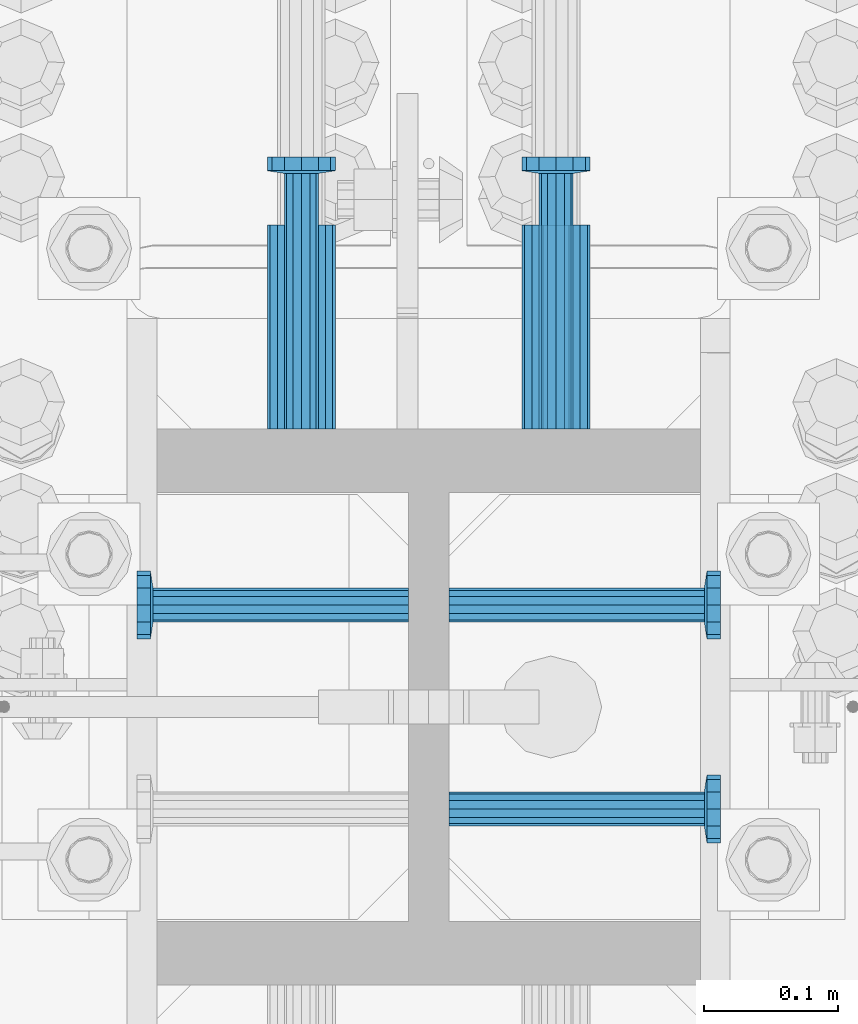
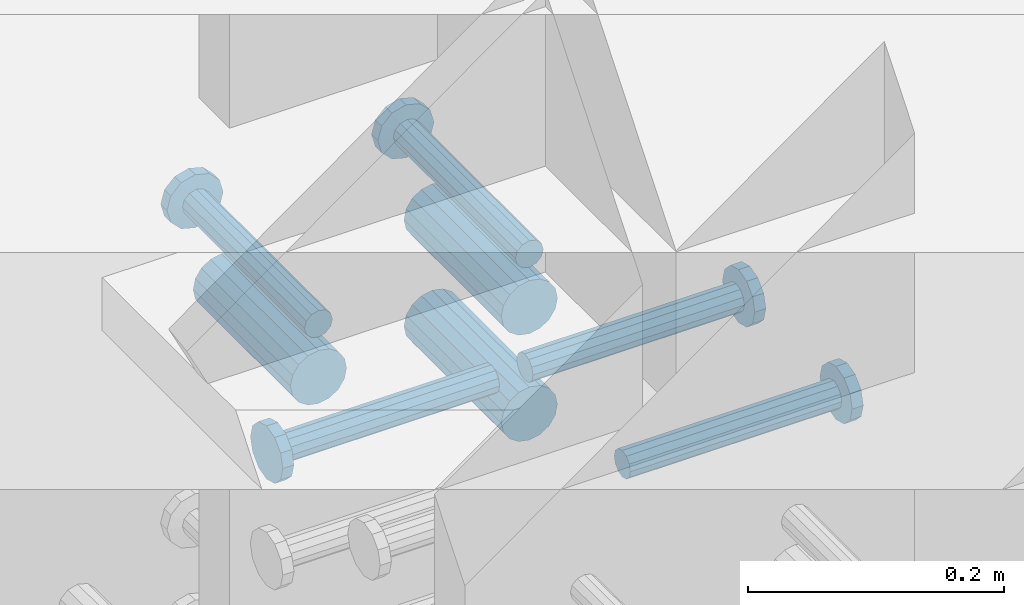
# One storey, part 1292 of 1763: 8 beams, 1 element without a shape of its own.
"""IFC2X3 building model written with IfcOpenShell, lengths in millimetres."""

from ifc_helpers import new_model, si_unit, frame, origin_with_axes, place, context, subcontext, project, spatial, faceted_brep, material, type_object, element, aggregate, save


model = new_model("IFC2X3")

# Units and contexts
model_context = context("Model", 3, precision=1e-05, world=origin_with_axes())
body_context = subcontext(model_context, "Body", "Model", "MODEL_VIEW")
ifc_project = project(units=[si_unit("LENGTHUNIT", "METRE", prefix="MILLI"), si_unit("AREAUNIT", "SQUARE_METRE"), si_unit("VOLUMEUNIT", "CUBIC_METRE"), si_unit("MASSUNIT", "GRAM", prefix="KILO"), si_unit("TIMEUNIT", "SECOND"), si_unit("PLANEANGLEUNIT", "RADIAN"), si_unit("SOLIDANGLEUNIT", "STERADIAN"), si_unit("THERMODYNAMICTEMPERATUREUNIT", "DEGREE_CELSIUS"), si_unit("LUMINOUSINTENSITYUNIT", "LUMEN")], contexts=[model_context])

# Site, building, storey
site_placement = place(None, origin_with_axes())
site = spatial("IfcSite", under=ifc_project, at=site_placement, CompositionType="ELEMENT")
building_placement = place(site_placement, origin_with_axes())
building = spatial("IfcBuilding", under=site, at=building_placement, Name="Undefined", CompositionType="ELEMENT")
storey_placement = place(building_placement, origin_with_axes())
storey = spatial("IfcBuildingStorey", under=building, at=storey_placement, Name="Undefined", CompositionType="ELEMENT", Elevation=0.0)

# Assembly, beams
assembly_placement = place(storey_placement, origin_with_axes())
assembly = element("IfcElementAssembly", 1, at=assembly_placement, inside=storey, Name="COLUMN", AssemblyPlace="NOTDEFINED", PredefinedType="RIGID_FRAME")
ifc_material_1 = material(Name="STEEL/A706-GR.80")
beam_type_1 = type_object("IfcBeamType", PredefinedType="NOTDEFINED")
beam_1_placement = place(assembly_placement, frame((-23932.5872736985, -13508.0376141552, 4775.20000000009), z_axis=(0.0, 0.0, 1.0), x_axis=(0.0, 1.0, 0.0)))
beam_1 = element("IfcBeam", 2, at=beam_1_placement, type_object=beam_type_1, material=ifc_material_1, Name="HALF COUPLER F", context=body_context, shape_type="Brep", body=[
    faceted_brep([(32.7659999999996, -8.95349999999962, -15.507916905568), (32.7659999999996, 0.0, -17.9070000000002), (32.7659999999996, 8.95349999999962, -15.507916905568), (32.7659999999996, 15.507916905568, -8.95350000000008), (32.7659999999996, 17.9069999999992, 0.0), (32.7659999999996, 15.507916905568, 8.95350000000008), (32.7659999999996, 8.95349999999962, 15.507916905568), (32.7659999999996, 0.0, 17.9070000000002), (32.7659999999996, -8.95349999999962, 15.507916905568), (32.7659999999996, -15.507916905568, 8.95350000000008), (32.7659999999996, -17.9069999999992, 0.0), (32.7659999999996, -15.507916905568, -8.95350000000008), (152.400103102711, -15.507916905568, 8.95350000000008), (152.400103102711, -8.95349999999962, 15.507916905568), (152.400103102711, -17.9069999999992, 0.0), (152.400103102711, -15.507916905568, -8.95350000000008), (152.400103102711, -8.95349999999962, -15.507916905568), (152.400103102711, 0.0, -17.9070000000002), (152.400103102711, 8.95349999999962, -15.507916905568), (152.400103102711, 15.507916905568, -8.95350000000008), (152.400103102711, 17.9069999999992, 0.0), (152.400103102711, 15.507916905568, 8.95350000000008), (152.400103102711, 8.95349999999962, 15.507916905568), (152.400103102711, 0.0, 17.9070000000002), (0.0, -23.466540125788, 9.72015918207308), (0.0, -17.9605122421381, 17.9605122421385), (0.0, -9.72015918207398, 23.4665401257867), (0.0, 0.0, 25.4000000000001), (0.0, 9.72015918207398, 23.4665401257867), (0.0, 17.9605122421381, 17.9605122421385), (0.0, 23.466540125788, 9.72015918207308), (0.0, 25.4000000000015, 0.0), (0.0, 23.466540125788, -9.72015918207308), (0.0, 17.9605122421381, -17.9605122421385), (0.0, 9.72015918207398, -23.4665401257867), (0.0, 0.0, -25.4000000000001), (0.0, -9.72015918207398, -23.4665401257867), (0.0, -17.9605122421381, -17.9605122421385), (0.0, -23.466540125788, -9.72015918207308), (0.0, -25.4000000000015, 0.0), (152.400103102711, -25.4000000000015, 0.0), (152.400103102711, -23.466540125788, 9.72015918207308), (152.400103102711, -17.9605122421381, 17.9605122421385), (152.400103102711, -9.72015918207398, 23.4665401257867), (152.400103102711, 0.0, 25.4000000000001), (152.400103102711, 9.72015918207398, 23.4665401257867), (152.400103102711, 17.9605122421381, 17.9605122421385), (152.400103102711, 23.466540125788, 9.72015918207308), (152.400103102711, 25.4000000000015, 0.0), (152.400103102711, 23.466540125788, -9.72015918207308), (152.400103102711, 17.9605122421381, -17.9605122421385), (152.400103102711, 9.72015918207398, -23.4665401257867), (152.400103102711, 0.0, -25.4000000000001), (152.400103102711, -9.72015918207398, -23.4665401257867), (152.400103102711, -17.9605122421381, -17.9605122421385), (152.400103102711, -23.466540125788, -9.72015918207308)], [[[0, 1, 2, 3, 4, 5, 6, 7, 8, 9, 10, 11]], [[12, 9, 8, 13]], [[14, 10, 9, 12]], [[15, 11, 10, 14]], [[16, 0, 11, 15]], [[17, 1, 0, 16]], [[18, 2, 1, 17]], [[19, 3, 2, 18]], [[20, 4, 3, 19]], [[21, 5, 4, 20]], [[22, 6, 5, 21]], [[23, 7, 6, 22]], [[13, 8, 7, 23]], [[24, 25, 26, 27, 28, 29, 30, 31, 32, 33, 34, 35, 36, 37, 38, 39]], [[24, 39, 40, 41]], [[25, 24, 41, 42]], [[26, 25, 42, 43]], [[27, 26, 43, 44]], [[28, 27, 44, 45]], [[29, 28, 45, 46]], [[30, 29, 46, 47]], [[31, 30, 47, 48]], [[32, 31, 48, 49]], [[33, 32, 49, 50]], [[34, 33, 50, 51]], [[35, 34, 51, 52]], [[36, 35, 52, 53]], [[37, 36, 53, 54]], [[38, 37, 54, 55]], [[39, 38, 55, 40]], [[54, 53, 52, 51, 50, 49, 48, 47, 46, 45, 44, 43, 42, 41, 40, 55], [21, 20, 19, 18, 17, 16, 15, 14, 12, 13, 23, 22]]]),
])
beam_2_placement = place(assembly_placement, frame((-24123.0872736984, -13508.0374079487, 4876.80000000009), z_axis=(0.0, 0.0, 1.0), x_axis=(0.0, 1.0, 0.0)))
beam_2 = element("IfcBeam", 3, at=beam_2_placement, type_object=beam_type_1, material=ifc_material_1, Name="HALF COUPLER F", context=body_context, shape_type="Brep", body=[
    faceted_brep([(32.7659999999996, -8.95349999999962, -15.507916905568), (32.7659999999996, 0.0, -17.9070000000002), (32.7659999999996, 8.95349999999962, -15.507916905568), (32.7659999999996, 15.507916905568, -8.95350000000008), (32.7659999999996, 17.9069999999992, 0.0), (32.7659999999996, 15.507916905568, 8.95350000000008), (32.7659999999996, 8.95349999999962, 15.507916905568), (32.7659999999996, 0.0, 17.9070000000002), (32.7659999999996, -8.95349999999962, 15.507916905568), (32.7659999999996, -15.507916905568, 8.95350000000008), (32.7659999999996, -17.9069999999992, 0.0), (32.7659999999996, -15.507916905568, -8.95350000000008), (152.400103102711, -15.507916905568, 8.95350000000008), (152.400103102711, -8.95349999999962, 15.507916905568), (152.400103102711, -17.9069999999992, 0.0), (152.400103102711, -15.507916905568, -8.95350000000008), (152.400103102711, -8.95349999999962, -15.507916905568), (152.400103102711, 0.0, -17.9070000000002), (152.400103102711, 8.95349999999962, -15.507916905568), (152.400103102711, 15.507916905568, -8.95350000000008), (152.400103102711, 17.9069999999992, 0.0), (152.400103102711, 15.507916905568, 8.95350000000008), (152.400103102711, 8.95349999999962, 15.507916905568), (152.400103102711, 0.0, 17.9070000000002), (0.0, -23.466540125788, 9.72015918207308), (0.0, -17.9605122421381, 17.9605122421385), (0.0, -9.72015918207398, 23.4665401257867), (0.0, 0.0, 25.4000000000001), (0.0, 9.72015918207398, 23.4665401257867), (0.0, 17.9605122421381, 17.9605122421385), (0.0, 23.466540125788, 9.72015918207308), (0.0, 25.4000000000015, 0.0), (0.0, 23.466540125788, -9.72015918207308), (0.0, 17.9605122421381, -17.9605122421385), (0.0, 9.72015918207398, -23.4665401257867), (0.0, 0.0, -25.4000000000001), (0.0, -9.72015918207398, -23.4665401257867), (0.0, -17.9605122421381, -17.9605122421385), (0.0, -23.466540125788, -9.72015918207308), (0.0, -25.4000000000015, 0.0), (152.400103102711, -25.4000000000015, 0.0), (152.400103102711, -23.466540125788, 9.72015918207308), (152.400103102711, -17.9605122421381, 17.9605122421385), (152.400103102711, -9.72015918207398, 23.4665401257867), (152.400103102711, 0.0, 25.4000000000001), (152.400103102711, 9.72015918207398, 23.4665401257867), (152.400103102711, 17.9605122421381, 17.9605122421385), (152.400103102711, 23.466540125788, 9.72015918207308), (152.400103102711, 25.4000000000015, 0.0), (152.400103102711, 23.466540125788, -9.72015918207308), (152.400103102711, 17.9605122421381, -17.9605122421385), (152.400103102711, 9.72015918207398, -23.4665401257867), (152.400103102711, 0.0, -25.4000000000001), (152.400103102711, -9.72015918207398, -23.4665401257867), (152.400103102711, -17.9605122421381, -17.9605122421385), (152.400103102711, -23.466540125788, -9.72015918207308)], [[[0, 1, 2, 3, 4, 5, 6, 7, 8, 9, 10, 11]], [[12, 9, 8, 13]], [[14, 10, 9, 12]], [[15, 11, 10, 14]], [[16, 0, 11, 15]], [[17, 1, 0, 16]], [[18, 2, 1, 17]], [[19, 3, 2, 18]], [[20, 4, 3, 19]], [[21, 5, 4, 20]], [[22, 6, 5, 21]], [[23, 7, 6, 22]], [[13, 8, 7, 23]], [[24, 25, 26, 27, 28, 29, 30, 31, 32, 33, 34, 35, 36, 37, 38, 39]], [[24, 39, 40, 41]], [[25, 24, 41, 42]], [[26, 25, 42, 43]], [[27, 26, 43, 44]], [[28, 27, 44, 45]], [[29, 28, 45, 46]], [[30, 29, 46, 47]], [[31, 30, 47, 48]], [[32, 31, 48, 49]], [[33, 32, 49, 50]], [[34, 33, 50, 51]], [[35, 34, 51, 52]], [[36, 35, 52, 53]], [[37, 36, 53, 54]], [[38, 37, 54, 55]], [[39, 38, 55, 40]], [[54, 53, 52, 51, 50, 49, 48, 47, 46, 45, 44, 43, 42, 41, 40, 55], [21, 20, 19, 18, 17, 16, 15, 14, 12, 13, 23, 22]]]),
])
beam_3_placement = place(assembly_placement, frame((-23932.5872736985, -13508.0374766842, 4876.80000000009), z_axis=(0.0, 0.0, 1.0), x_axis=(0.0, 1.0, 0.0)))
beam_3 = element("IfcBeam", 4, at=beam_3_placement, type_object=beam_type_1, material=ifc_material_1, Name="HALF COUPLER F", context=body_context, shape_type="Brep", body=[
    faceted_brep([(32.7659999999996, -8.95349999999962, -15.507916905568), (32.7659999999996, 0.0, -17.9070000000002), (32.7659999999996, 8.95349999999962, -15.507916905568), (32.7659999999996, 15.507916905568, -8.95350000000008), (32.7659999999996, 17.9069999999992, 0.0), (32.7659999999996, 15.507916905568, 8.95350000000008), (32.7659999999996, 8.95349999999962, 15.507916905568), (32.7659999999996, 0.0, 17.9070000000002), (32.7659999999996, -8.95349999999962, 15.507916905568), (32.7659999999996, -15.507916905568, 8.95350000000008), (32.7659999999996, -17.9069999999992, 0.0), (32.7659999999996, -15.507916905568, -8.95350000000008), (152.400103102711, -15.507916905568, 8.95350000000008), (152.400103102711, -8.95349999999962, 15.507916905568), (152.400103102711, -17.9069999999992, 0.0), (152.400103102711, -15.507916905568, -8.95350000000008), (152.400103102711, -8.95349999999962, -15.507916905568), (152.400103102711, 0.0, -17.9070000000002), (152.400103102711, 8.95349999999962, -15.507916905568), (152.400103102711, 15.507916905568, -8.95350000000008), (152.400103102711, 17.9069999999992, 0.0), (152.400103102711, 15.507916905568, 8.95350000000008), (152.400103102711, 8.95349999999962, 15.507916905568), (152.400103102711, 0.0, 17.9070000000002), (0.0, -23.466540125788, 9.72015918207308), (0.0, -17.9605122421381, 17.9605122421385), (0.0, -9.72015918207398, 23.4665401257867), (0.0, 0.0, 25.4000000000001), (0.0, 9.72015918207398, 23.4665401257867), (0.0, 17.9605122421381, 17.9605122421385), (0.0, 23.466540125788, 9.72015918207308), (0.0, 25.4000000000015, 0.0), (0.0, 23.466540125788, -9.72015918207308), (0.0, 17.9605122421381, -17.9605122421385), (0.0, 9.72015918207398, -23.4665401257867), (0.0, 0.0, -25.4000000000001), (0.0, -9.72015918207398, -23.4665401257867), (0.0, -17.9605122421381, -17.9605122421385), (0.0, -23.466540125788, -9.72015918207308), (0.0, -25.4000000000015, 0.0), (152.400103102711, -25.4000000000015, 0.0), (152.400103102711, -23.466540125788, 9.72015918207308), (152.400103102711, -17.9605122421381, 17.9605122421385), (152.400103102711, -9.72015918207398, 23.4665401257867), (152.400103102711, 0.0, 25.4000000000001), (152.400103102711, 9.72015918207398, 23.4665401257867), (152.400103102711, 17.9605122421381, 17.9605122421385), (152.400103102711, 23.466540125788, 9.72015918207308), (152.400103102711, 25.4000000000015, 0.0), (152.400103102711, 23.466540125788, -9.72015918207308), (152.400103102711, 17.9605122421381, -17.9605122421385), (152.400103102711, 9.72015918207398, -23.4665401257867), (152.400103102711, 0.0, -25.4000000000001), (152.400103102711, -9.72015918207398, -23.4665401257867), (152.400103102711, -17.9605122421381, -17.9605122421385), (152.400103102711, -23.466540125788, -9.72015918207308)], [[[0, 1, 2, 3, 4, 5, 6, 7, 8, 9, 10, 11]], [[12, 9, 8, 13]], [[14, 10, 9, 12]], [[15, 11, 10, 14]], [[16, 0, 11, 15]], [[17, 1, 0, 16]], [[18, 2, 1, 17]], [[19, 3, 2, 18]], [[20, 4, 3, 19]], [[21, 5, 4, 20]], [[22, 6, 5, 21]], [[23, 7, 6, 22]], [[13, 8, 7, 23]], [[24, 25, 26, 27, 28, 29, 30, 31, 32, 33, 34, 35, 36, 37, 38, 39]], [[24, 39, 40, 41]], [[25, 24, 41, 42]], [[26, 25, 42, 43]], [[27, 26, 43, 44]], [[28, 27, 44, 45]], [[29, 28, 45, 46]], [[30, 29, 46, 47]], [[31, 30, 47, 48]], [[32, 31, 48, 49]], [[33, 32, 49, 50]], [[34, 33, 50, 51]], [[35, 34, 51, 52]], [[36, 35, 52, 53]], [[37, 36, 53, 54]], [[38, 37, 54, 55]], [[39, 38, 55, 40]], [[54, 53, 52, 51, 50, 49, 48, 47, 46, 45, 44, 43, 42, 41, 40, 55], [21, 20, 19, 18, 17, 16, 15, 14, 12, 13, 23, 22]]]),
])
ifc_material_2 = material(Name="STEEL/A108")
beam_type_2 = type_object("IfcBeamType", PredefinedType="NOTDEFINED")
beam_4_placement = place(assembly_placement, frame((-24012.7560236984, -13792.1998618628, 4927.60000000008), z_axis=(0.0, -1.0, 0.0), x_axis=(1.0, 0.0, 0.0)))
beam_4 = element("IfcBeam", 5, at=beam_4_placement, type_object=beam_type_2, material=ifc_material_2, Name="HEADED STUD ANCHOR", context=body_context, shape_type="Brep", body=[
    faceted_brep([(0.0, -12.6999999999971, -1.81898940354586e-12), (3.63797880709171e-12, -11.0, -6.34999990463257), (191.00799999576, -11.0, -6.34999990454889), (191.007999995752, -12.6999998092651, 8.36735125631094e-11), (7.27595761418343e-12, -6.34999990463257, -11.0), (191.00799999576, -6.34999990463257, -10.9999999999163), (3.63797880709171e-12, 0.0, -12.6999998092651), (191.00799999576, 0.0, -12.6999998091815), (7.27595761418343e-12, 6.34999990463257, -11.0), (191.00799999576, 6.34999990463257, -10.9999999999163), (3.63797880709171e-12, 11.0, -6.34999990463257), (191.00799999576, 11.0, -6.34999990454889), (0.0, 12.6999999999971, -1.81898940354586e-12), (191.007999995752, 12.6999998092651, 8.36735125631094e-11), (0.0, 11.0, 6.34999990463257), (191.007999995752, 11.0, 6.34999990471624), (-3.63797880709171e-12, 6.34999990463257, 11.0), (191.007999995749, 6.34999990463257, 11.0000000000837), (-3.63797880709171e-12, 0.0, 12.6999998092651), (191.007999995749, 0.0, 12.6999998093488), (-3.63797880709171e-12, -6.34999990463257, 11.0), (191.007999995749, -6.34999990463257, 11.0000000000837), (0.0, -11.0, 6.34999990463257), (191.007999995752, -11.0, 6.34999990471624), (193.039999995715, -22.0, -12.6999998091796), (193.039999995708, -25.3999996185303, 8.54925019666553e-11), (193.039999995719, -12.6999998092651, -21.9999999999145), (193.039999995719, 0.0, -25.3999996184448), (193.039999995719, 12.6999998092651, -21.9999999999145), (193.039999995715, 22.0, -12.6999998091796), (193.039999995708, 25.3999996185303, 8.54925019666553e-11), (193.039999995704, 22.0, 12.6999998093506), (193.039999995701, 12.6999998092651, 22.0000000000855), (193.039999995697, 0.0, 25.3999996186158), (193.039999995701, -12.6999998092651, 22.0000000000855), (193.039999995704, -22.0, 12.6999998093506), (203.199999995486, -22.0, -12.6999998091742), (203.199999995482, -25.3999996185303, 9.09494701772928e-11), (203.199999995493, -12.6999998092651, -21.9999999999091), (203.199999995493, 0.0, -25.3999996184393), (203.199999995493, 12.6999998092651, -21.9999999999091), (203.199999995486, 22.0, -12.6999998091742), (203.199999995482, 25.3999996185303, 9.09494701772928e-11), (203.199999995479, 22.0, 12.6999998093561), (203.199999995475, 12.6999998092651, 22.0000000000909), (203.199999995471, 0.0, 25.3999996186212), (203.199999995475, -12.6999998092651, 22.0000000000909), (203.199999995479, -22.0, 12.6999998093561)], [[[0, 1, 2, 3]], [[1, 4, 5, 2]], [[4, 6, 7, 5]], [[6, 8, 9, 7]], [[8, 10, 11, 9]], [[10, 12, 13, 11]], [[12, 14, 15, 13]], [[14, 16, 17, 15]], [[16, 18, 19, 17]], [[18, 20, 21, 19]], [[20, 22, 23, 21]], [[22, 0, 3, 23]], [[22, 20, 18, 16, 14, 12, 10, 8, 6, 4, 1, 0]], [[3, 2, 24, 25]], [[2, 5, 26, 24]], [[5, 7, 27, 26]], [[7, 9, 28, 27]], [[9, 11, 29, 28]], [[11, 13, 30, 29]], [[13, 15, 31, 30]], [[15, 17, 32, 31]], [[17, 19, 33, 32]], [[19, 21, 34, 33]], [[21, 23, 35, 34]], [[23, 3, 25, 35]], [[25, 24, 36, 37]], [[24, 26, 38, 36]], [[26, 27, 39, 38]], [[27, 28, 40, 39]], [[28, 29, 41, 40]], [[29, 30, 42, 41]], [[30, 31, 43, 42]], [[31, 32, 44, 43]], [[32, 33, 45, 44]], [[33, 34, 46, 45]], [[34, 35, 47, 46]], [[35, 25, 37, 47]], [[38, 39, 40, 41, 42, 43, 44, 45, 46, 47, 37, 36]]]),
])
beam_5_placement = place(assembly_placement, frame((-24012.7560246955, -13639.7998618631, 4927.60000000008), z_axis=(0.0, -1.0, 0.0), x_axis=(1.0, 0.0, 0.0)))
beam_5 = element("IfcBeam", 6, at=beam_5_placement, type_object=beam_type_2, material=ifc_material_2, Name="HEADED STUD ANCHOR", context=body_context, shape_type="Brep", body=[
    faceted_brep([(0.0, -12.6999999999971, -1.81898940354586e-12), (3.63797880709171e-12, -11.0, -6.34999990463257), (191.00799999576, -11.0, -6.34999990454889), (191.007999995752, -12.6999998092651, 8.36735125631094e-11), (7.27595761418343e-12, -6.34999990463257, -11.0), (191.00799999576, -6.34999990463257, -10.9999999999163), (3.63797880709171e-12, 0.0, -12.6999998092651), (191.00799999576, 0.0, -12.6999998091815), (7.27595761418343e-12, 6.34999990463257, -11.0), (191.00799999576, 6.34999990463257, -10.9999999999163), (3.63797880709171e-12, 11.0, -6.34999990463257), (191.00799999576, 11.0, -6.34999990454889), (0.0, 12.6999999999971, -1.81898940354586e-12), (191.007999995752, 12.6999998092651, 8.36735125631094e-11), (0.0, 11.0, 6.34999990463257), (191.007999995752, 11.0, 6.34999990471624), (-3.63797880709171e-12, 6.34999990463257, 11.0), (191.007999995749, 6.34999990463257, 11.0000000000837), (-3.63797880709171e-12, 0.0, 12.6999998092651), (191.007999995749, 0.0, 12.6999998093488), (-3.63797880709171e-12, -6.34999990463257, 11.0), (191.007999995749, -6.34999990463257, 11.0000000000837), (0.0, -11.0, 6.34999990463257), (191.007999995752, -11.0, 6.34999990471624), (193.039999995715, -22.0, -12.6999998091796), (193.039999995708, -25.3999996185303, 8.54925019666553e-11), (193.039999995719, -12.6999998092651, -21.9999999999145), (193.039999995719, 0.0, -25.3999996184448), (193.039999995719, 12.6999998092651, -21.9999999999145), (193.039999995715, 22.0, -12.6999998091796), (193.039999995708, 25.3999996185303, 8.54925019666553e-11), (193.039999995704, 22.0, 12.6999998093506), (193.039999995701, 12.6999998092651, 22.0000000000855), (193.039999995697, 0.0, 25.3999996186158), (193.039999995701, -12.6999998092651, 22.0000000000855), (193.039999995704, -22.0, 12.6999998093506), (203.199999995486, -22.0, -12.6999998091742), (203.199999995482, -25.3999996185303, 9.09494701772928e-11), (203.199999995493, -12.6999998092651, -21.9999999999091), (203.199999995493, 0.0, -25.3999996184393), (203.199999995493, 12.6999998092651, -21.9999999999091), (203.199999995486, 22.0, -12.6999998091742), (203.199999995482, 25.3999996185303, 9.09494701772928e-11), (203.199999995479, 22.0, 12.6999998093561), (203.199999995475, 12.6999998092651, 22.0000000000909), (203.199999995471, 0.0, 25.3999996186212), (203.199999995475, -12.6999998092651, 22.0000000000909), (203.199999995479, -22.0, 12.6999998093561)], [[[0, 1, 2, 3]], [[1, 4, 5, 2]], [[4, 6, 7, 5]], [[6, 8, 9, 7]], [[8, 10, 11, 9]], [[10, 12, 13, 11]], [[12, 14, 15, 13]], [[14, 16, 17, 15]], [[16, 18, 19, 17]], [[18, 20, 21, 19]], [[20, 22, 23, 21]], [[22, 0, 3, 23]], [[22, 20, 18, 16, 14, 12, 10, 8, 6, 4, 1, 0]], [[3, 2, 24, 25]], [[2, 5, 26, 24]], [[5, 7, 27, 26]], [[7, 9, 28, 27]], [[9, 11, 29, 28]], [[11, 13, 30, 29]], [[13, 15, 31, 30]], [[15, 17, 32, 31]], [[17, 19, 33, 32]], [[19, 21, 34, 33]], [[21, 23, 35, 34]], [[23, 3, 25, 35]], [[25, 24, 36, 37]], [[24, 26, 38, 36]], [[26, 27, 39, 38]], [[27, 28, 40, 39]], [[28, 29, 41, 40]], [[29, 30, 42, 41]], [[30, 31, 43, 42]], [[31, 32, 44, 43]], [[32, 33, 45, 44]], [[33, 34, 46, 45]], [[34, 35, 47, 46]], [[35, 25, 37, 47]], [[38, 39, 40, 41, 42, 43, 44, 45, 46, 47, 37, 36]]]),
])
beam_6_placement = place(assembly_placement, frame((-23932.5872736985, -13508.0375000001, 4927.60000000008), z_axis=(1.0, 0.0, 0.0), x_axis=(0.0, 1.0, 0.0)))
beam_6 = element("IfcBeam", 7, at=beam_6_placement, type_object=beam_type_2, material=ifc_material_2, Name="HEADED STUD ANCHOR", context=body_context, shape_type="Brep", body=[
    faceted_brep([(0.0, -12.6999999999971, -1.81898940354586e-12), (3.63797880709171e-12, -11.0, -6.34999990463257), (191.00799999576, -11.0, -6.34999990454889), (191.007999995752, -12.6999998092651, 8.36735125631094e-11), (7.27595761418343e-12, -6.34999990463257, -11.0), (191.00799999576, -6.34999990463257, -10.9999999999163), (3.63797880709171e-12, 0.0, -12.6999998092651), (191.00799999576, 0.0, -12.6999998091815), (7.27595761418343e-12, 6.34999990463257, -11.0), (191.00799999576, 6.34999990463257, -10.9999999999163), (3.63797880709171e-12, 11.0, -6.34999990463257), (191.00799999576, 11.0, -6.34999990454889), (0.0, 12.6999999999971, -1.81898940354586e-12), (191.007999995752, 12.6999998092651, 8.36735125631094e-11), (0.0, 11.0, 6.34999990463257), (191.007999995752, 11.0, 6.34999990471624), (-3.63797880709171e-12, 6.34999990463257, 11.0), (191.007999995749, 6.34999990463257, 11.0000000000837), (-3.63797880709171e-12, 0.0, 12.6999998092651), (191.007999995749, 0.0, 12.6999998093488), (-3.63797880709171e-12, -6.34999990463257, 11.0), (191.007999995749, -6.34999990463257, 11.0000000000837), (0.0, -11.0, 6.34999990463257), (191.007999995752, -11.0, 6.34999990471624), (193.039999995715, -22.0, -12.6999998091796), (193.039999995708, -25.3999996185303, 8.54925019666553e-11), (193.039999995719, -12.6999998092651, -21.9999999999145), (193.039999995719, 0.0, -25.3999996184448), (193.039999995719, 12.6999998092651, -21.9999999999145), (193.039999995715, 22.0, -12.6999998091796), (193.039999995708, 25.3999996185303, 8.54925019666553e-11), (193.039999995704, 22.0, 12.6999998093506), (193.039999995701, 12.6999998092651, 22.0000000000855), (193.039999995697, 0.0, 25.3999996186158), (193.039999995701, -12.6999998092651, 22.0000000000855), (193.039999995704, -22.0, 12.6999998093506), (203.199999995486, -22.0, -12.6999998091742), (203.199999995482, -25.3999996185303, 9.09494701772928e-11), (203.199999995493, -12.6999998092651, -21.9999999999091), (203.199999995493, 0.0, -25.3999996184393), (203.199999995493, 12.6999998092651, -21.9999999999091), (203.199999995486, 22.0, -12.6999998091742), (203.199999995482, 25.3999996185303, 9.09494701772928e-11), (203.199999995479, 22.0, 12.6999998093561), (203.199999995475, 12.6999998092651, 22.0000000000909), (203.199999995471, 0.0, 25.3999996186212), (203.199999995475, -12.6999998092651, 22.0000000000909), (203.199999995479, -22.0, 12.6999998093561)], [[[0, 1, 2, 3]], [[1, 4, 5, 2]], [[4, 6, 7, 5]], [[6, 8, 9, 7]], [[8, 10, 11, 9]], [[10, 12, 13, 11]], [[12, 14, 15, 13]], [[14, 16, 17, 15]], [[16, 18, 19, 17]], [[18, 20, 21, 19]], [[20, 22, 23, 21]], [[22, 0, 3, 23]], [[22, 20, 18, 16, 14, 12, 10, 8, 6, 4, 1, 0]], [[3, 2, 24, 25]], [[2, 5, 26, 24]], [[5, 7, 27, 26]], [[7, 9, 28, 27]], [[9, 11, 29, 28]], [[11, 13, 30, 29]], [[13, 15, 31, 30]], [[15, 17, 32, 31]], [[17, 19, 33, 32]], [[19, 21, 34, 33]], [[21, 23, 35, 34]], [[23, 3, 25, 35]], [[25, 24, 36, 37]], [[24, 26, 38, 36]], [[26, 27, 39, 38]], [[27, 28, 40, 39]], [[28, 29, 41, 40]], [[29, 30, 42, 41]], [[30, 31, 43, 42]], [[31, 32, 44, 43]], [[32, 33, 45, 44]], [[33, 34, 46, 45]], [[34, 35, 47, 46]], [[35, 25, 37, 47]], [[38, 39, 40, 41, 42, 43, 44, 45, 46, 47, 37, 36]]]),
])
beam_7_placement = place(assembly_placement, frame((-24123.0872736984, -13508.0374312646, 4927.60000000008), z_axis=(1.0, 0.0, 0.0), x_axis=(0.0, 1.0, 0.0)))
beam_7 = element("IfcBeam", 8, at=beam_7_placement, type_object=beam_type_2, material=ifc_material_2, Name="HEADED STUD ANCHOR", context=body_context, shape_type="Brep", body=[
    faceted_brep([(0.0, -12.6999999999971, -1.81898940354586e-12), (3.63797880709171e-12, -11.0, -6.34999990463257), (191.00799999576, -11.0, -6.34999990454889), (191.007999995752, -12.6999998092651, 8.36735125631094e-11), (7.27595761418343e-12, -6.34999990463257, -11.0), (191.00799999576, -6.34999990463257, -10.9999999999163), (3.63797880709171e-12, 0.0, -12.6999998092651), (191.00799999576, 0.0, -12.6999998091815), (7.27595761418343e-12, 6.34999990463257, -11.0), (191.00799999576, 6.34999990463257, -10.9999999999163), (3.63797880709171e-12, 11.0, -6.34999990463257), (191.00799999576, 11.0, -6.34999990454889), (0.0, 12.6999999999971, -1.81898940354586e-12), (191.007999995752, 12.6999998092651, 8.36735125631094e-11), (0.0, 11.0, 6.34999990463257), (191.007999995752, 11.0, 6.34999990471624), (-3.63797880709171e-12, 6.34999990463257, 11.0), (191.007999995749, 6.34999990463257, 11.0000000000837), (-3.63797880709171e-12, 0.0, 12.6999998092651), (191.007999995749, 0.0, 12.6999998093488), (-3.63797880709171e-12, -6.34999990463257, 11.0), (191.007999995749, -6.34999990463257, 11.0000000000837), (0.0, -11.0, 6.34999990463257), (191.007999995752, -11.0, 6.34999990471624), (193.039999995715, -22.0, -12.6999998091796), (193.039999995708, -25.3999996185303, 8.54925019666553e-11), (193.039999995719, -12.6999998092651, -21.9999999999145), (193.039999995719, 0.0, -25.3999996184448), (193.039999995719, 12.6999998092651, -21.9999999999145), (193.039999995715, 22.0, -12.6999998091796), (193.039999995708, 25.3999996185303, 8.54925019666553e-11), (193.039999995704, 22.0, 12.6999998093506), (193.039999995701, 12.6999998092651, 22.0000000000855), (193.039999995697, 0.0, 25.3999996186158), (193.039999995701, -12.6999998092651, 22.0000000000855), (193.039999995704, -22.0, 12.6999998093506), (203.199999995486, -22.0, -12.6999998091742), (203.199999995482, -25.3999996185303, 9.09494701772928e-11), (203.199999995493, -12.6999998092651, -21.9999999999091), (203.199999995493, 0.0, -25.3999996184393), (203.199999995493, 12.6999998092651, -21.9999999999091), (203.199999995486, 22.0, -12.6999998091742), (203.199999995482, 25.3999996185303, 9.09494701772928e-11), (203.199999995479, 22.0, 12.6999998093561), (203.199999995475, 12.6999998092651, 22.0000000000909), (203.199999995471, 0.0, 25.3999996186212), (203.199999995475, -12.6999998092651, 22.0000000000909), (203.199999995479, -22.0, 12.6999998093561)], [[[0, 1, 2, 3]], [[1, 4, 5, 2]], [[4, 6, 7, 5]], [[6, 8, 9, 7]], [[8, 10, 11, 9]], [[10, 12, 13, 11]], [[12, 14, 15, 13]], [[14, 16, 17, 15]], [[16, 18, 19, 17]], [[18, 20, 21, 19]], [[20, 22, 23, 21]], [[22, 0, 3, 23]], [[22, 20, 18, 16, 14, 12, 10, 8, 6, 4, 1, 0]], [[3, 2, 24, 25]], [[2, 5, 26, 24]], [[5, 7, 27, 26]], [[7, 9, 28, 27]], [[9, 11, 29, 28]], [[11, 13, 30, 29]], [[13, 15, 31, 30]], [[15, 17, 32, 31]], [[17, 19, 33, 32]], [[19, 21, 34, 33]], [[21, 23, 35, 34]], [[23, 3, 25, 35]], [[25, 24, 36, 37]], [[24, 26, 38, 36]], [[26, 27, 39, 38]], [[27, 28, 40, 39]], [[28, 29, 41, 40]], [[29, 30, 42, 41]], [[30, 31, 43, 42]], [[31, 32, 44, 43]], [[32, 33, 45, 44]], [[33, 34, 46, 45]], [[34, 35, 47, 46]], [[35, 25, 37, 47]], [[38, 39, 40, 41, 42, 43, 44, 45, 46, 47, 37, 36]]]),
])
beam_8_placement = place(assembly_placement, frame((-24042.9185299162, -13639.7998628716, 4927.60000000008), z_axis=(0.0, -1.0, 0.0), x_axis=(-1.0, 0.0, 0.0)))
beam_8 = element("IfcBeam", 9, at=beam_8_placement, type_object=beam_type_2, material=ifc_material_2, Name="HEADED STUD ANCHOR", context=body_context, shape_type="Brep", body=[
    faceted_brep([(0.0, -12.6999999999971, -1.81898940354586e-12), (3.63797880709171e-12, -11.0, -6.34999990463257), (191.00799999576, -11.0, -6.34999990454889), (191.007999995752, -12.6999998092651, 8.36735125631094e-11), (7.27595761418343e-12, -6.34999990463257, -11.0), (191.00799999576, -6.34999990463257, -10.9999999999163), (3.63797880709171e-12, 0.0, -12.6999998092651), (191.00799999576, 0.0, -12.6999998091815), (7.27595761418343e-12, 6.34999990463257, -11.0), (191.00799999576, 6.34999990463257, -10.9999999999163), (3.63797880709171e-12, 11.0, -6.34999990463257), (191.00799999576, 11.0, -6.34999990454889), (0.0, 12.6999999999971, -1.81898940354586e-12), (191.007999995752, 12.6999998092651, 8.36735125631094e-11), (0.0, 11.0, 6.34999990463257), (191.007999995752, 11.0, 6.34999990471624), (-3.63797880709171e-12, 6.34999990463257, 11.0), (191.007999995749, 6.34999990463257, 11.0000000000837), (-3.63797880709171e-12, 0.0, 12.6999998092651), (191.007999995749, 0.0, 12.6999998093488), (-3.63797880709171e-12, -6.34999990463257, 11.0), (191.007999995749, -6.34999990463257, 11.0000000000837), (0.0, -11.0, 6.34999990463257), (191.007999995752, -11.0, 6.34999990471624), (193.039999995715, -22.0, -12.6999998091796), (193.039999995708, -25.3999996185303, 8.54925019666553e-11), (193.039999995719, -12.6999998092651, -21.9999999999145), (193.039999995719, 0.0, -25.3999996184448), (193.039999995719, 12.6999998092651, -21.9999999999145), (193.039999995715, 22.0, -12.6999998091796), (193.039999995708, 25.3999996185303, 8.54925019666553e-11), (193.039999995704, 22.0, 12.6999998093506), (193.039999995701, 12.6999998092651, 22.0000000000855), (193.039999995697, 0.0, 25.3999996186158), (193.039999995701, -12.6999998092651, 22.0000000000855), (193.039999995704, -22.0, 12.6999998093506), (203.199999995486, -22.0, -12.6999998091742), (203.199999995482, -25.3999996185303, 9.09494701772928e-11), (203.199999995493, -12.6999998092651, -21.9999999999091), (203.199999995493, 0.0, -25.3999996184393), (203.199999995493, 12.6999998092651, -21.9999999999091), (203.199999995486, 22.0, -12.6999998091742), (203.199999995482, 25.3999996185303, 9.09494701772928e-11), (203.199999995479, 22.0, 12.6999998093561), (203.199999995475, 12.6999998092651, 22.0000000000909), (203.199999995471, 0.0, 25.3999996186212), (203.199999995475, -12.6999998092651, 22.0000000000909), (203.199999995479, -22.0, 12.6999998093561)], [[[0, 1, 2, 3]], [[1, 4, 5, 2]], [[4, 6, 7, 5]], [[6, 8, 9, 7]], [[8, 10, 11, 9]], [[10, 12, 13, 11]], [[12, 14, 15, 13]], [[14, 16, 17, 15]], [[16, 18, 19, 17]], [[18, 20, 21, 19]], [[20, 22, 23, 21]], [[22, 0, 3, 23]], [[22, 20, 18, 16, 14, 12, 10, 8, 6, 4, 1, 0]], [[3, 2, 24, 25]], [[2, 5, 26, 24]], [[5, 7, 27, 26]], [[7, 9, 28, 27]], [[9, 11, 29, 28]], [[11, 13, 30, 29]], [[13, 15, 31, 30]], [[15, 17, 32, 31]], [[17, 19, 33, 32]], [[19, 21, 34, 33]], [[21, 23, 35, 34]], [[23, 3, 25, 35]], [[25, 24, 36, 37]], [[24, 26, 38, 36]], [[26, 27, 39, 38]], [[27, 28, 40, 39]], [[28, 29, 41, 40]], [[29, 30, 42, 41]], [[30, 31, 43, 42]], [[31, 32, 44, 43]], [[32, 33, 45, 44]], [[33, 34, 46, 45]], [[34, 35, 47, 46]], [[35, 25, 37, 47]], [[38, 39, 40, 41, 42, 43, 44, 45, 46, 47, 37, 36]]]),
])
aggregate(assembly, [beam_1, beam_2, beam_3, beam_4, beam_5, beam_6, beam_7, beam_8])

save(model, "model.ifc")
